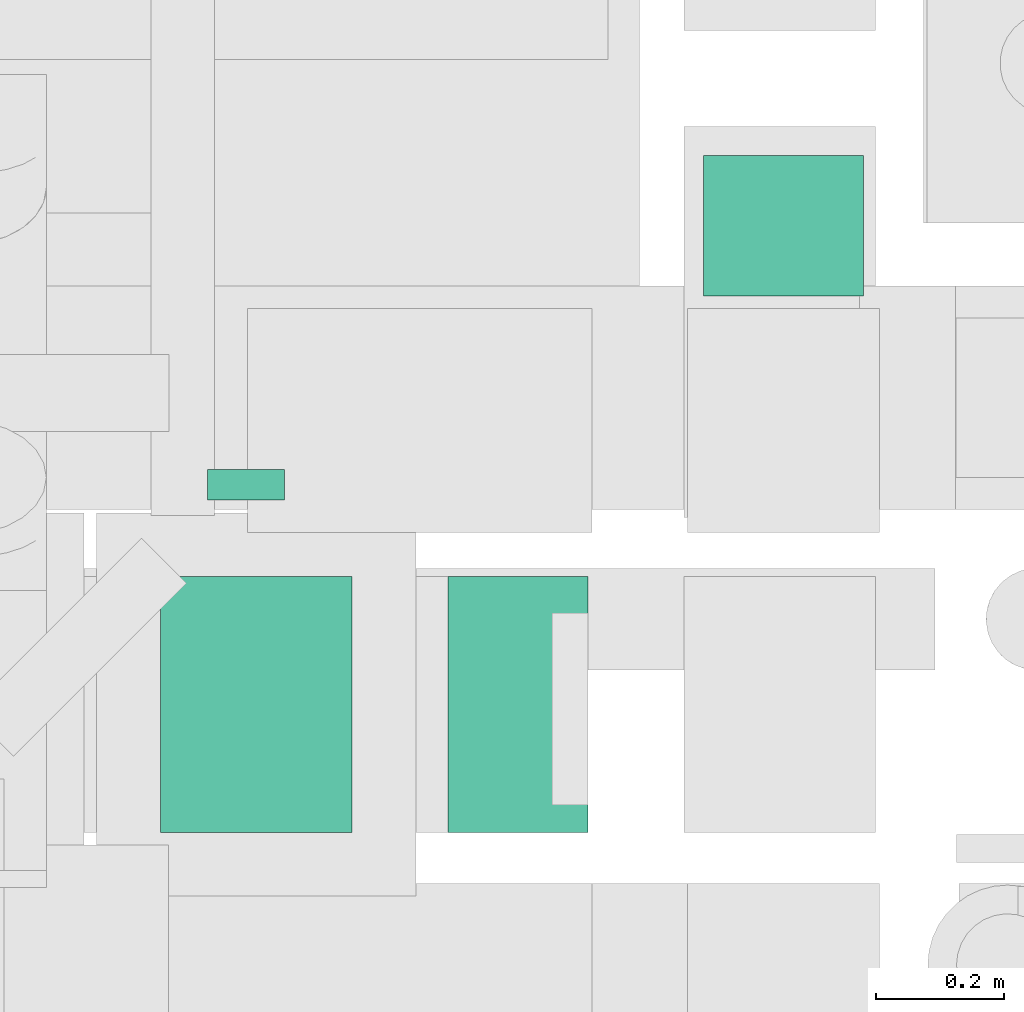
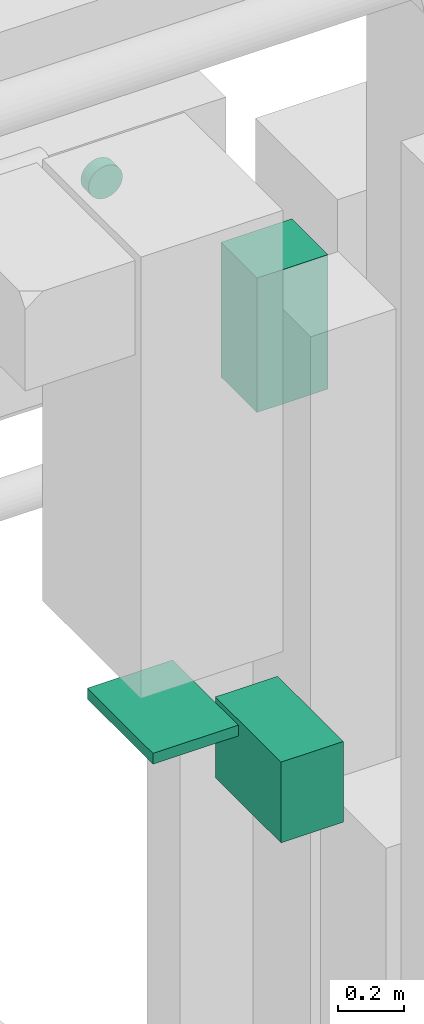
# One storey, part 145 of 337: 4 flow segments.
"""IFC2X3 building model written with IfcOpenShell, lengths in millimetres."""

from ifc_helpers import new_model, entity, si_unit, converted_unit, derived_unit, direction, frame, origin, origin_2d_with_axis, place, context, subcontext, project, spatial, rectangle, circle, extrude, type_object, element, save


model = new_model("IFC2X3")

# Units and contexts
model_context = context("Model", 3, precision=0.01, world=origin(), true_north=direction((6.12303176911189e-17, 1.0)))
body_context = subcontext(model_context, "Body", "Model", "MODEL_VIEW")
ifc_project = project(units=[si_unit("LENGTHUNIT", "METRE", prefix="MILLI"), si_unit("AREAUNIT", "SQUARE_METRE"), si_unit("VOLUMEUNIT", "CUBIC_METRE"), converted_unit("PLANEANGLEUNIT", "DEGREE", entity("IfcRatioMeasure", 0.0174532925199433), si_unit("PLANEANGLEUNIT", "RADIAN"), dimensions=[0, 0, 0, 0, 0, 0, 0]), si_unit("MASSUNIT", "GRAM", prefix="KILO"), derived_unit("MASSDENSITYUNIT", [(si_unit("MASSUNIT", "GRAM", prefix="KILO"), 1), (si_unit("LENGTHUNIT", "METRE"), -3)]), derived_unit("MOMENTOFINERTIAUNIT", [(si_unit("LENGTHUNIT", "METRE"), 4)]), si_unit("TIMEUNIT", "SECOND"), si_unit("FREQUENCYUNIT", "HERTZ"), si_unit("THERMODYNAMICTEMPERATUREUNIT", "DEGREE_CELSIUS"), derived_unit("THERMALTRANSMITTANCEUNIT", [(si_unit("MASSUNIT", "GRAM", prefix="KILO"), 1), (si_unit("THERMODYNAMICTEMPERATUREUNIT", "KELVIN"), -1), (si_unit("TIMEUNIT", "SECOND"), -3)]), derived_unit("VOLUMETRICFLOWRATEUNIT", [(si_unit("LENGTHUNIT", "METRE"), 3), (si_unit("TIMEUNIT", "SECOND"), -1)]), derived_unit("MASSFLOWRATEUNIT", [(si_unit("MASSUNIT", "GRAM", prefix="KILO"), 1), (si_unit("TIMEUNIT", "SECOND"), -1)]), derived_unit("ROTATIONALFREQUENCYUNIT", [(si_unit("TIMEUNIT", "SECOND"), -1)]), si_unit("ELECTRICCURRENTUNIT", "AMPERE"), si_unit("ELECTRICVOLTAGEUNIT", "VOLT"), si_unit("POWERUNIT", "WATT"), si_unit("FORCEUNIT", "NEWTON", prefix="KILO"), si_unit("ILLUMINANCEUNIT", "LUX"), si_unit("LUMINOUSFLUXUNIT", "LUMEN"), si_unit("LUMINOUSINTENSITYUNIT", "CANDELA"), derived_unit("USERDEFINED", [(si_unit("MASSUNIT", "GRAM", prefix="KILO"), -1), (si_unit("LENGTHUNIT", "METRE"), -2), (si_unit("TIMEUNIT", "SECOND"), 3), (si_unit("LUMINOUSFLUXUNIT", "LUMEN"), 1)]), derived_unit("LINEARVELOCITYUNIT", [(si_unit("LENGTHUNIT", "METRE"), 1), (si_unit("TIMEUNIT", "SECOND"), -1)]), si_unit("PRESSUREUNIT", "PASCAL"), derived_unit("USERDEFINED", [(si_unit("LENGTHUNIT", "METRE"), -2), (si_unit("MASSUNIT", "GRAM", prefix="KILO"), 1), (si_unit("TIMEUNIT", "SECOND"), -2)]), derived_unit("LINEARFORCEUNIT", [(si_unit("MASSUNIT", "GRAM", prefix="KILO"), 1), (si_unit("LENGTHUNIT", "METRE"), 1), (si_unit("TIMEUNIT", "SECOND"), -2), (si_unit("LENGTHUNIT", "METRE"), -1)]), derived_unit("PLANARFORCEUNIT", [(si_unit("MASSUNIT", "GRAM", prefix="KILO"), 1), (si_unit("LENGTHUNIT", "METRE"), 1), (si_unit("TIMEUNIT", "SECOND"), -2), (si_unit("LENGTHUNIT", "METRE"), -2)])], contexts=[model_context])

# Site, building, storey
site_placement = place(None, origin())
site = spatial("IfcSite", under=ifc_project, at=site_placement, CompositionType="ELEMENT")
building_placement = place(site_placement, origin())
building = spatial("IfcBuilding", under=site, at=building_placement, CompositionType="ELEMENT")
storey_placement = place(building_placement, origin())
storey = spatial("IfcBuildingStorey", under=building, at=storey_placement, CompositionType="ELEMENT", Elevation=0.0)

# Flow segments
duct_segment_type_1 = type_object("IfcDuctSegmentType", PredefinedType="NOTDEFINED")
flow_segment_1_placement = place(storey_placement, frame((31015.11, 12684.49, 29550.01)))
element("IfcFlowSegment", 1, at=flow_segment_1_placement, inside=storey, type_object=duct_segment_type_1, context=body_context, shape_type="SweptSolid", body=[
    extrude(rectangle(XDim=220.000000076818, YDim=249.999999999999, at=origin_2d_with_axis()), frame((125.0, 110.0, 0.0), z_axis=(0.0, 0.0, 1.0), x_axis=(0.0, -1.0, 0.0)), (0.0, 0.0, 1.0), 499.999999999999),
])
duct_segment_type_2 = type_object("IfcDuctSegmentType", PredefinedType="NOTDEFINED")
flow_segment_2_placement = place(storey_placement, frame((30237.01, 12365.06, 30790.48)))
element("IfcFlowSegment", 2, at=flow_segment_2_placement, inside=storey, type_object=duct_segment_type_2, context=body_context, shape_type="SweptSolid", body=[
    extrude(circle(Radius=60.0, at=origin_2d_with_axis()), frame((61.6, 0.0, 61.6), z_axis=(0.0, 1.0, 0.0), x_axis=(1.0, 0.0, 0.0)), (0.0, 0.0, 1.0), 47.5000002837437),
])
duct_segment_type_3 = type_object("IfcDuctSegmentType", PredefinedType="NOTDEFINED")
flow_segment_3_placement = place(storey_placement, frame((30165.03, 11845.06, 29050.0)))
element("IfcFlowSegment", 3, at=flow_segment_3_placement, inside=storey, type_object=duct_segment_type_3, context=body_context, shape_type="SweptSolid", body=[
    extrude(rectangle(XDim=300.000000000001, YDim=400.0, at=origin_2d_with_axis()), frame((150.0, 200.0, 0.0), z_axis=(0.0, 0.0, 1.0), x_axis=(-1.0, 0.0, 0.0)), (0.0, 0.0, 1.0), 39.9999750000281),
])
flow_segment_4_placement = place(storey_placement, frame((30615.03, 11845.06, 28600.0)))
element("IfcFlowSegment", 4, at=flow_segment_4_placement, inside=storey, type_object=duct_segment_type_3, context=body_context, shape_type="SweptSolid", body=[
    extrude(rectangle(XDim=219.251985000051, YDim=400.0, at=origin_2d_with_axis()), frame((109.63, 200.0, 0.0)), (0.0, 0.0, 1.0), 300.000000000001),
])

save(model, "model.ifc")
